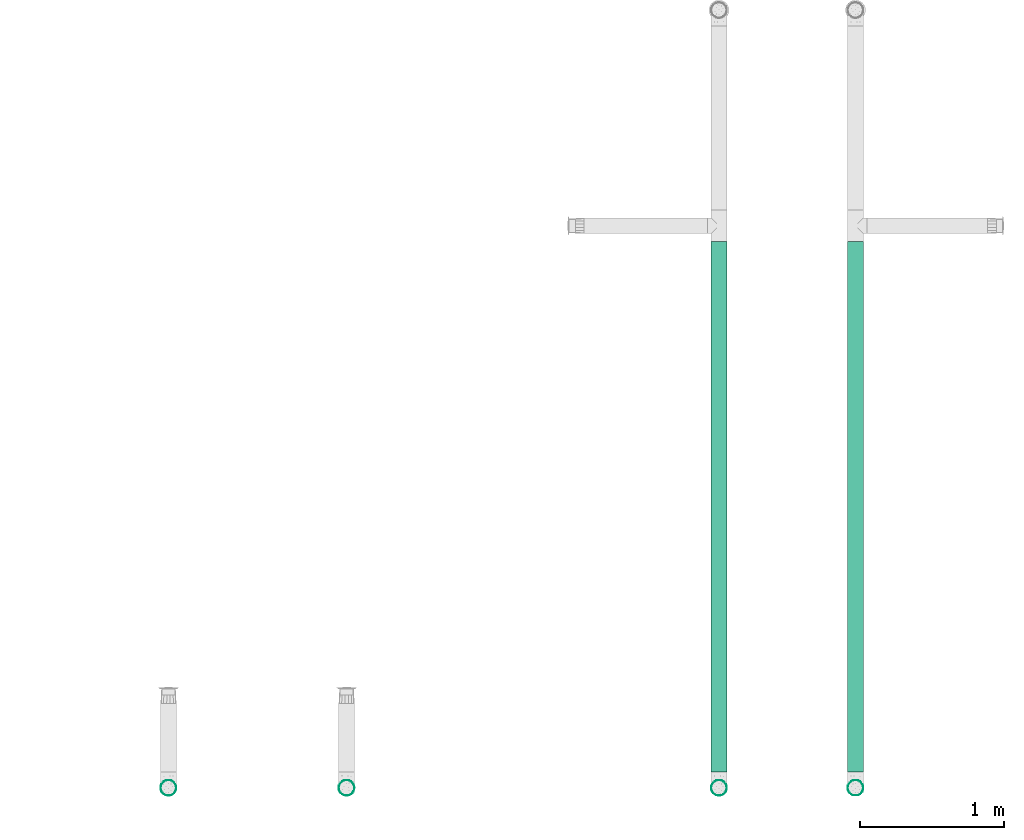
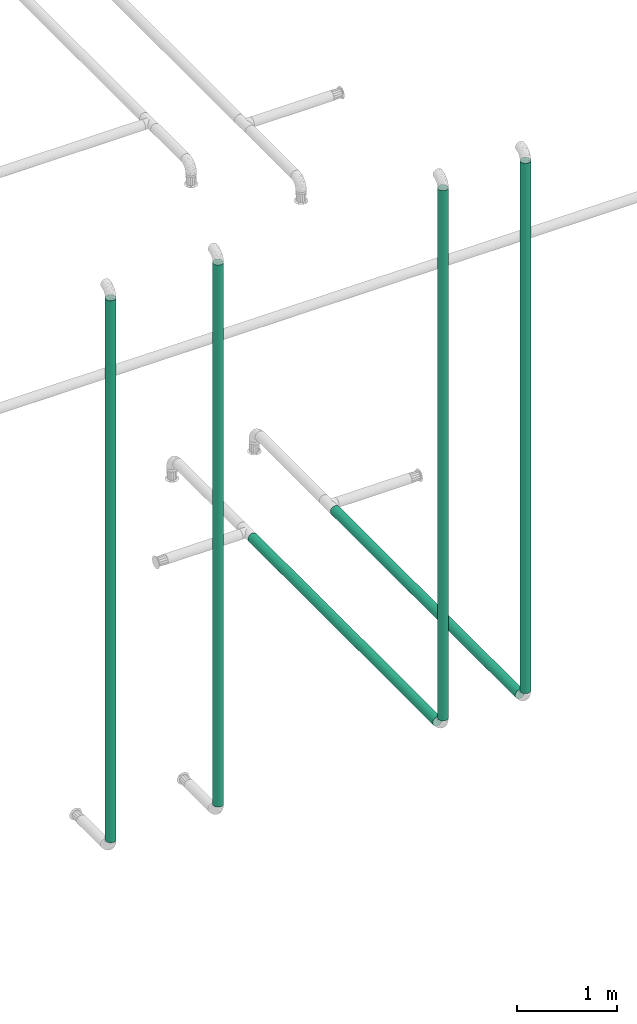
# One storey, part 2 of 123: 6 flow segments.
"""IFC2X3 building model written with IfcOpenShell, lengths in millimetres."""

from ifc_helpers import new_model, entity, si_unit, converted_unit, derived_unit, direction, frame, origin_with_axes, origin_2d_with_axis, place, context, subcontext, project, spatial, hollow_circle, extrude, source, transform, mapped, material, layer, layer_set, layer_usage, type_object, element, save


model = new_model("IFC2X3")

# Units and contexts
model_context = context("Model", 3, precision=1e-05, world=origin_with_axes(), true_north=direction((0.0, 1.0)))
body_context = subcontext(model_context, "Body", "Model", "MODEL_VIEW")
ifc_project = project(units=[si_unit("AREAUNIT", "SQUARE_METRE"), si_unit("VOLUMEUNIT", "CUBIC_METRE", prefix="DECI"), si_unit("TIMEUNIT", "SECOND"), si_unit("THERMODYNAMICTEMPERATUREUNIT", "DEGREE_CELSIUS"), si_unit("PRESSUREUNIT", "PASCAL"), si_unit("MASSUNIT", "GRAM", prefix="KILO"), si_unit("LENGTHUNIT", "METRE", prefix="MILLI"), si_unit("POWERUNIT", "WATT"), si_unit("ELECTRICCURRENTUNIT", "AMPERE"), si_unit("ELECTRICVOLTAGEUNIT", "VOLT"), derived_unit("VOLUMETRICFLOWRATEUNIT", [(si_unit("VOLUMEUNIT", "CUBIC_METRE", prefix="DECI"), 1), (si_unit("TIMEUNIT", "SECOND"), -1)]), derived_unit("LINEARVELOCITYUNIT", [(si_unit("LENGTHUNIT", "METRE"), 1), (si_unit("TIMEUNIT", "SECOND"), -1)]), derived_unit("MASSDENSITYUNIT", [(si_unit("MASSUNIT", "GRAM", prefix="KILO"), 1), (si_unit("VOLUMEUNIT", "CUBIC_METRE"), -1)]), converted_unit("PLANEANGLEUNIT", "DEGREE", entity("IfcRatioMeasure", 0.01745), si_unit("PLANEANGLEUNIT", "RADIAN"), dimensions=[0, 0, 0, 0, 0, 0, 0])], contexts=[model_context])

# Site, building, storey
site_placement = place(None, origin_with_axes())
site = spatial("IfcSite", under=ifc_project, at=site_placement, CompositionType="ELEMENT")
building_placement = place(site_placement, origin_with_axes())
building = spatial("IfcBuilding", under=site, at=building_placement, Name="mc-building", CompositionType="ELEMENT")
storey_placement = place(building_placement, origin_with_axes())
storey = spatial("IfcBuildingStorey", under=building, at=storey_placement, Name="1. Korrus", CompositionType="ELEMENT", Elevation=0.0)

# Flow segments
ifc_material = material(Name="FZ1")
ifc_layer = layer(ifc_material, 0.0)
ifc_layer_set = layer_set([ifc_layer], Name="FZ1")
ifc_layer_usage = layer_usage(ifc_layer_set, "AXIS1", "POSITIVE", 0.0)
duct_segment_type_1 = type_object("IfcDuctSegmentType", Name="Safe", PredefinedType="RIGIDSEGMENT")
shared_shape_1 = source(origin_with_axes(), body_context, "Body", "SweptSolid", [
    extrude(hollow_circle(Radius=55.0, WallThickness=2.0, at=origin_2d_with_axis()), frame((0.0, 0.0, 0.0), z_axis=(1.0, 0.0, 0.0), x_axis=(0.0, 1.0, 0.0)), (0.0, 0.0, 1.0), 6595.0),
])
for number, where, z_axis, x_axis, name in (
    (1, (12930.40917, -687.64676, 2410.0), (0.0, 1.0, 0.0), (0.0, 0.0, 1.0), "Safe"),
    (2, (11692.81055, -687.64676, 2410.0), (0.0, 1.0, 0.0), (0.0, 0.0, 1.0), "Safe"),
):
    element("IfcFlowSegment", number, at=place(storey_placement, frame(where, z_axis=z_axis, x_axis=x_axis)), inside=storey, type_object=duct_segment_type_1, material=ifc_layer_usage, Name=name, context=body_context, shape_type="MappedRepresentation", body=[
        mapped(shared_shape_1, transform((0.0, 0.0, 0.0), scale=1.0)),
    ])
duct_segment_type_2 = type_object("IfcDuctSegmentType", PredefinedType="RIGIDSEGMENT")
shared_shape_2 = source(origin_with_axes(), body_context, "Body", "SweptSolid", [
    extrude(hollow_circle(Radius=55.0, WallThickness=2.0, at=origin_2d_with_axis()), frame((0.0, 0.0, 0.0), z_axis=(1.0, 0.0, 0.0), x_axis=(0.0, 1.0, 0.0)), (0.0, 0.0, 1.0), 3685.5),
])
for number, where, z_axis, x_axis in (
    (3, (16466.11947, -577.64676, 2445.0), (0.0, 0.0, 1.0), (0.0, 1.0, 0.0)),
    (4, (15517.82156, -577.64676, 2445.0), (0.0, 0.0, 1.0), (0.0, 1.0, 0.0)),
):
    element("IfcFlowSegment", number, at=place(storey_placement, frame(where, z_axis=z_axis, x_axis=x_axis)), inside=storey, type_object=duct_segment_type_2, material=ifc_layer_usage, context=body_context, shape_type="MappedRepresentation", body=[
        mapped(shared_shape_2, transform((0.0, 0.0, 0.0), scale=1.0)),
    ])
shared_shape_3 = source(origin_with_axes(), body_context, "Body", "SweptSolid", [
    extrude(hollow_circle(Radius=55.0, WallThickness=2.0, at=origin_2d_with_axis()), frame((0.0, 0.0, 0.0), z_axis=(1.0, 0.0, 0.0), x_axis=(0.0, 1.0, 0.0)), (0.0, 0.0, 1.0), 6450.0),
])
for number, where, z_axis, x_axis in (
    (5, (16466.11947, -687.64676, 2555.0), (0.0, 1.0, 0.0), (0.0, 0.0, 1.0)),
    (6, (15517.82156, -687.64676, 2555.0), (0.0, 1.0, 0.0), (0.0, 0.0, 1.0)),
):
    element("IfcFlowSegment", number, at=place(storey_placement, frame(where, z_axis=z_axis, x_axis=x_axis)), inside=storey, type_object=duct_segment_type_2, material=ifc_layer_usage, context=body_context, shape_type="MappedRepresentation", body=[
        mapped(shared_shape_3, transform((0.0, 0.0, 0.0), scale=1.0)),
    ])

save(model, "model.ifc")
